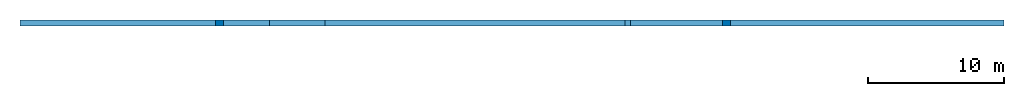
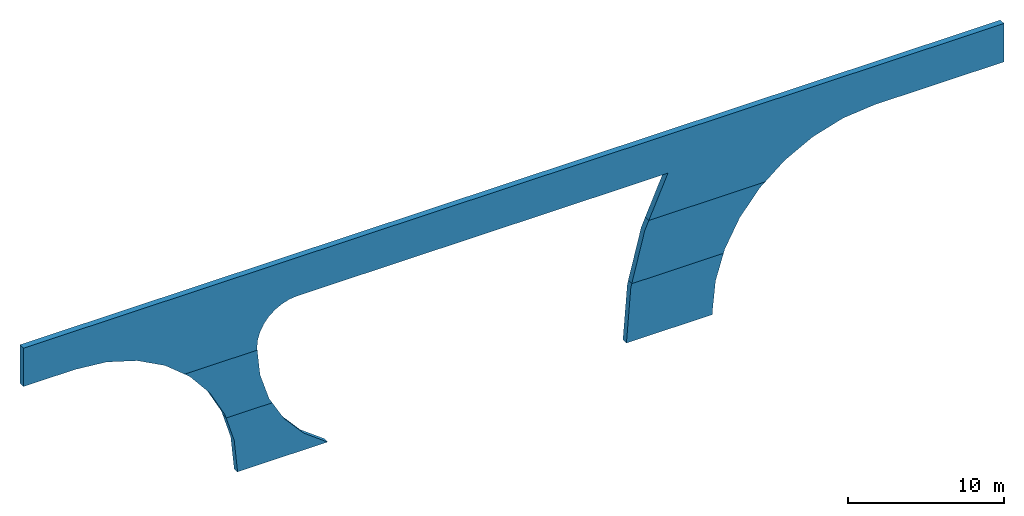
# Not in any storey: 3 walls, 9 openings.
"""IFC2X3 building model written with IfcOpenShell, lengths in millimetres."""

from ifc_helpers import new_model, entity, si_unit, converted_unit, derived_unit, direction, frame, origin_with_axes, place, context, subcontext, project, spatial, polyline, outline, extrude, faceted_brep, material, element, save


model = new_model("IFC2X3")

# Units and contexts
model_context = context("Model", 3, precision=0.1, world=origin_with_axes(), true_north=direction((0.0, 1.0)))
body_context = subcontext(model_context, "Body", "Model", "MODEL_VIEW", scale=1.0)
ifc_project = project(units=[si_unit("LENGTHUNIT", "METRE", prefix="MILLI"), si_unit("AREAUNIT", "SQUARE_METRE"), si_unit("VOLUMEUNIT", "CUBIC_METRE"), converted_unit("PLANEANGLEUNIT", "DEGREE", entity("IfcPlaneAngleMeasure", 0.0174532925199433), si_unit("PLANEANGLEUNIT", "RADIAN"), dimensions=[0, 0, 0, 0, 0, 0, 0]), si_unit("TIMEUNIT", "SECOND"), si_unit("MASSUNIT", "GRAM", prefix="KILO"), si_unit("THERMODYNAMICTEMPERATUREUNIT", "KELVIN"), derived_unit("THERMALTRANSMITTANCEUNIT", [(si_unit("POWERUNIT", "WATT"), 1), (si_unit("AREAUNIT", "SQUARE_METRE"), -1), (si_unit("THERMODYNAMICTEMPERATUREUNIT", "KELVIN"), -1)])], contexts=[model_context])

# Building
building_placement = place(None, origin_with_axes())
building = spatial("IfcBuilding", under=ifc_project, at=building_placement, CompositionType="ELEMENT")

# Wall, openings
ifc_material = material(Name="C30/37")
wall_1_placement = place(building_placement, frame((66919.2217480221, -20755.9758084029, -398.522529797108), z_axis=(3.91446519643068e-09, -1.0, 0.0), x_axis=(1.0, 3.91446519643068e-09, 0.0)))
wall_1 = element("IfcWall", 1, at=wall_1_placement, inside=building, material=ifc_material, Name="Concrete Panel", context=body_context, shape_type="SweptSolid", body=[
    extrude(outline(polyline([(0.0, 0.0), (72450.0000000238, 0.0), (72450.0000000238, 6200.0), (0.0, 6200.0), (0.0, 0.0)])), frame((-36224.9999982504, 6200.0, -450.000141801502), z_axis=(3.91446519643068e-09, 0.0, -1.0), x_axis=(1.0, 0.0, 3.91446519643068e-09)), (0.0, 0.0, -1.0), 450.0),
])
opening_1_placement = place(wall_1_placement, frame((25449.9948862458, -2899.49498149954, -10450.0000000596), z_axis=(0.0, 0.0, 1.0), x_axis=(0.0, -1.0, 0.0)))
element("IfcOpeningElement", 2, at=opening_1_placement, cuts=wall_1, Name="Poly Cut", ObjectType="Opening", context=body_context, shape_type="Brep", body=[
    faceted_brep([(5900.50501843965, -10775.005113723, -1.81898940354586e-12), (6099.50501848878, -10775.005113758, -1.81898940354586e-12), (6099.50501848878, -10775.005113758, 20000.0), (5900.50501843965, -10775.005113723, 20000.0), (6099.50501850185, 10775.0051137568, -1.81898940354586e-12), (6099.50501850185, 10775.0051137568, 20000.0), (-6099.50501850185, 10775.005113758, -1.81898940354586e-12), (-6099.50501850185, 10775.005113758, 20000.0), (-6099.50498156031, 1225.00488627701, 0.0), (-6099.50498156031, 1225.00488627701, 20000.0), (-5868.92815425188, -1116.08092881959, -1.81898940354586e-12), (-5868.92815425188, -1116.08092881959, 20000.0), (-5186.05861049108, -3367.20012893822, -1.81898940354586e-12), (-5186.05861049108, -3367.20012893822, 20000.0), (-4077.13864388699, -5441.84346566035, -1.81898940354586e-12), (-4077.13864388699, -5441.84346566035, 20000.0), (-2584.78342686672, -7260.28355902917, 0.0), (-2584.78342686672, -7260.28355902917, 20000.0), (-766.343333497909, -8752.63877604944, -3.63797880709171e-12), (-766.343333497909, -8752.63877604944, 20000.0), (1308.30000322423, -9861.55874265351, 20000.0), (3559.41920334285, -10544.4282864143, 20000.0), (3559.41920334285, -10544.4282864143, -1.81898940354586e-12), (1308.30000322423, -9861.55874265351, 0.0)], [[[0, 1, 2, 3]], [[1, 4, 5, 2]], [[4, 6, 7, 5]], [[6, 8, 9, 7]], [[8, 10, 11, 9]], [[10, 12, 13, 11]], [[12, 14, 15, 13]], [[14, 16, 17, 15]], [[16, 18, 19, 17]], [[3, 2, 5, 7, 9, 11, 13, 15, 17, 19, 20, 21]], [[6, 4, 1, 0, 22, 23, 18, 16, 14, 12, 10, 8]], [[18, 23, 20, 19]], [[23, 22, 21, 20]], [[22, 0, 3, 21]]]),
])
opening_2_placement = place(wall_1_placement, frame((-3790.85290190091, -2899.49499952649, -10449.9999999967), z_axis=(0.0, 0.0, 1.0), x_axis=(0.0, -1.0, 0.0)))
element("IfcOpeningElement", 3, at=opening_2_placement, cuts=wall_1, Name="Poly Cut", ObjectType="Opening", context=body_context, shape_type="Brep", body=[
    faceted_brep([(6099.50499853983, -9963.96619154037, 20000.0), (4777.63446104734, -11733.0569945356, 20000.0), (4777.63446104734, -11733.0569945356, -1.81898940354586e-12), (6099.50499853983, -9963.96619154037, -1.81898940354586e-12), (3121.17396848015, -13193.5920415978, 20000.0), (3121.17396848015, -13193.5920415978, 0.0), (1200.48354787124, -14283.5334598924, 20000.0), (1200.48354787124, -14283.5334598924, 0.0), (-902.853309641485, -14956.5847588002, 20000.0), (-902.853309641485, -14956.5847588002, -1.81898940354586e-12), (-3099.49499958409, -15184.1573255542, 20000.0), (-3099.49499958409, -15184.1573255542, -1.81898940354586e-12), (-3684.76791653575, -15126.5129746142, 20000.0), (-3684.76791653575, -15126.5129746142, -1.81898940354586e-12), (-4247.54912351376, -14955.7951618809, 20000.0), (-4247.54912351376, -14955.7951618809, -1.81898940354586e-12), (-4766.21125434532, -14678.5644771555, 20000.0), (-4766.21125434532, -14678.5644771555, -1.81898940354586e-12), (-5220.82241421165, -14305.4747401791, 20000.0), (-5220.82241421165, -14305.4747401791, -1.81898940354586e-12), (-5593.91215118796, -13850.8635803128, 20000.0), (-5593.91215118796, -13850.8635803128, -1.81898940354586e-12), (-5871.1428359134, -13332.2014494812, 20000.0), (-5871.1428359134, -13332.2014494812, -1.81898940354586e-12), (-6041.86064864671, -12769.4202425032, 20000.0), (-6041.86064864671, -12769.4202425032, -1.81898940354586e-12), (-6099.50499958422, -12184.1473255516, 20000.0), (-6099.50499958422, -12184.1473255516, 0.0), (-6099.50499958443, 15184.1573255373, 20000.0), (-6099.50499958443, 15184.1573255373, -1.81898940354586e-12), (-2226.97816684917, 13473.8663299848, 20000.0), (-2226.97816684917, 13473.8663299848, -1.81898940354586e-12), (6099.50499958582, 12116.6546873007, 20000.0), (1878.60032757103, 12441.4978948431, 20000.0), (6099.50499958582, 12116.6546873007, 0.0), (1878.60032757103, 12441.4978948431, -1.81898940354586e-12)], [[[0, 1, 2, 3]], [[1, 4, 5, 2]], [[4, 6, 7, 5]], [[6, 8, 9, 7]], [[8, 10, 11, 9]], [[10, 12, 13, 11]], [[12, 14, 15, 13]], [[14, 16, 17, 15]], [[16, 18, 19, 17]], [[18, 20, 21, 19]], [[20, 22, 23, 21]], [[22, 24, 25, 23]], [[24, 26, 27, 25]], [[26, 28, 29, 27]], [[28, 30, 31, 29]], [[1, 0, 32, 33, 30, 28, 26, 24, 22, 20, 18, 16, 14, 12, 10, 8, 6, 4]], [[34, 3, 2, 5, 7, 9, 11, 13, 15, 17, 19, 21, 23, 25, 27, 29, 31, 35]], [[30, 33, 35, 31]], [[33, 32, 34, 35]], [[32, 0, 3, 34]]]),
])
opening_3_placement = place(wall_1_placement, frame((-28324.9951984067, -2899.95706100758, -10449.9999999762), z_axis=(0.0, 0.0, 1.0), x_axis=(0.0, -1.0, 0.0)))
element("IfcOpeningElement", 4, at=opening_3_placement, cuts=wall_1, Name="Poly Cut", ObjectType="Opening", context=body_context, shape_type="Brep", body=[
    faceted_brep([(6099.96706100289, 7900.00497090482, 0.0), (5900.04293893701, 7900.00497091756, 0.0), (5900.04293893701, 7900.00497091756, 20000.0), (6099.96706100289, 7900.00497090482, 20000.0), (3558.95712384023, 7669.42814360913, 0.0), (3558.95712384023, 7669.42814360913, 20000.0), (1307.83792372158, 6986.55859984832, 0.0), (1307.83792372158, 6986.55859984832, 20000.0), (-766.805413000579, 5877.63863324423, 1.81898940354586e-12), (-766.805413000579, 5877.63863324423, 20000.0), (-2585.24550636941, 4385.28341622394, 0.0), (-2585.24550636941, 4385.28341622394, 20000.0), (-4077.6007233897, 2566.84332285511, 0.0), (-4077.6007233897, 2566.84332285511, 20000.0), (-5186.52068999381, 492.199986132939, 1.81898940354586e-12), (-5186.52068999381, 492.199986132939, 20000.0), (-5869.39023375461, -1758.91921398571, 0.0), (-5869.39023375461, -1758.91921398571, 20000.0), (-6099.96706106299, -4100.00502908244, 1.81898940354586e-12), (-6099.96706106299, -4100.00502908244, 20000.0), (6099.96706106305, -7900.00497091755, 20000.0), (-6099.96706106305, -7900.00494477663, 20000.0), (6099.96706106305, -7900.00497091755, 0.0), (-6099.96706106305, -7900.00494477663, 0.0)], [[[0, 1, 2, 3]], [[1, 4, 5, 2]], [[4, 6, 7, 5]], [[6, 8, 9, 7]], [[8, 10, 11, 9]], [[10, 12, 13, 11]], [[12, 14, 15, 13]], [[14, 16, 17, 15]], [[16, 18, 19, 17]], [[20, 3, 2, 5, 7, 9, 11, 13, 15, 17, 19, 21]], [[1, 0, 22, 23, 18, 16, 14, 12, 10, 8, 6, 4]], [[18, 23, 21, 19]], [[23, 22, 20, 21]], [[22, 0, 3, 20]]]),
])

wall_2_placement = place(building_placement, frame((66919.2217480221, -20755.9758084029, -4897.52252979711), z_axis=(3.91446519643068e-09, -1.0, 0.0), x_axis=(1.0, 3.91446519643068e-09, 0.0)))
wall_2 = element("IfcWall", 5, at=wall_2_placement, inside=building, material=ifc_material, Name="Concrete Panel", context=body_context, shape_type="SweptSolid", body=[
    extrude(outline(polyline([(0.0, 0.0), (72450.0000000239, 0.0), (72450.0000000239, 4500.0), (0.0, 4500.0), (0.0, 0.0)])), frame((-36224.9999982504, 4500.0, -450.000141801502), z_axis=(3.91446519643068e-09, 0.0, -1.0), x_axis=(1.0, 0.0, 3.91446519643068e-09)), (0.0, 0.0, -1.0), 450.0),
])
opening_4_placement = place(wall_2_placement, frame((-28324.9951984067, 1599.04293899242, -10450.0000000147), z_axis=(0.0, 0.0, 1.0), x_axis=(0.0, -1.0, 0.0)))
element("IfcOpeningElement", 6, at=opening_4_placement, cuts=wall_2, Name="Poly Cut", ObjectType="Opening", context=body_context, shape_type="Brep", body=[
    faceted_brep([(6099.96706100289, 7900.00497090482, 0.0), (5900.04293893701, 7900.00497091756, 0.0), (5900.04293893701, 7900.00497091756, 20000.0), (6099.96706100289, 7900.00497090482, 20000.0), (3558.95712384023, 7669.42814360913, 1.81898940354586e-12), (3558.95712384023, 7669.42814360913, 20000.0), (1307.83792372158, 6986.55859984832, 1.81898940354586e-12), (1307.83792372158, 6986.55859984832, 20000.0), (-766.805413000579, 5877.63863324423, 1.81898940354586e-12), (-766.805413000579, 5877.63863324423, 20000.0), (-2585.24550636941, 4385.28341622394, 0.0), (-2585.24550636941, 4385.28341622394, 20000.0), (-4077.6007233897, 2566.84332285511, 0.0), (-4077.6007233897, 2566.84332285511, 20000.0), (-5186.52068999381, 492.199986132939, 1.81898940354586e-12), (-5186.52068999381, 492.199986132939, 20000.0), (-5869.39023375461, -1758.91921398571, 0.0), (-5869.39023375461, -1758.91921398571, 20000.0), (-6099.96706106299, -4100.00502908244, 1.81898940354586e-12), (-6099.96706106299, -4100.00502908244, 20000.0), (6099.96706106305, -7900.00497091755, 20000.0), (-6099.96706106305, -7900.00494477663, 20000.0), (6099.96706106305, -7900.00497091755, 0.0), (-6099.96706106305, -7900.00494477663, 0.0)], [[[0, 1, 2, 3]], [[1, 4, 5, 2]], [[4, 6, 7, 5]], [[6, 8, 9, 7]], [[8, 10, 11, 9]], [[10, 12, 13, 11]], [[12, 14, 15, 13]], [[14, 16, 17, 15]], [[16, 18, 19, 17]], [[20, 3, 2, 5, 7, 9, 11, 13, 15, 17, 19, 21]], [[1, 0, 22, 23, 18, 16, 14, 12, 10, 8, 6, 4]], [[18, 23, 21, 19]], [[23, 22, 20, 21]], [[22, 0, 3, 20]]]),
])
opening_5_placement = place(wall_2_placement, frame((-3790.85290190091, 1599.50500047351, -10449.9999999905), z_axis=(0.0, 0.0, 1.0), x_axis=(0.0, -1.0, 0.0)))
element("IfcOpeningElement", 7, at=opening_5_placement, cuts=wall_2, Name="Poly Cut", ObjectType="Opening", context=body_context, shape_type="Brep", body=[
    faceted_brep([(6099.50499853983, -9963.96619154037, 20000.0), (4777.63446104734, -11733.0569945356, 20000.0), (4777.63446104734, -11733.0569945356, -1.81898940354586e-12), (6099.50499853983, -9963.96619154037, -1.81898940354586e-12), (3121.17396848015, -13193.5920415978, 20000.0), (3121.17396848015, -13193.5920415978, 1.81898940354586e-12), (1200.48354787124, -14283.5334598924, 20000.0), (1200.48354787124, -14283.5334598924, 0.0), (-902.853309641485, -14956.5847588002, 20000.0), (-902.853309641485, -14956.5847588002, 0.0), (-3099.49499958409, -15184.1573255542, 20000.0), (-3099.49499958409, -15184.1573255542, 0.0), (-3684.76791653575, -15126.5129746142, 20000.0), (-3684.76791653575, -15126.5129746142, 0.0), (-4247.54912351376, -14955.7951618809, 20000.0), (-4247.54912351376, -14955.7951618809, -1.81898940354586e-12), (-4766.21125434532, -14678.5644771555, 20000.0), (-4766.21125434532, -14678.5644771555, 0.0), (-5220.82241421165, -14305.4747401791, 20000.0), (-5220.82241421165, -14305.4747401791, 0.0), (-5593.91215118796, -13850.8635803128, 20000.0), (-5593.91215118796, -13850.8635803128, 0.0), (-5871.1428359134, -13332.2014494812, 20000.0), (-5871.1428359134, -13332.2014494812, 0.0), (-6041.86064864671, -12769.4202425032, 20000.0), (-6041.86064864671, -12769.4202425032, -1.81898940354586e-12), (-6099.50499958422, -12184.1473255516, 20000.0), (-6099.50499958422, -12184.1473255516, 0.0), (-6099.50499958443, 15184.1573255373, 20000.0), (-6099.50499958443, 15184.1573255373, 0.0), (-2226.97816684917, 13473.8663299848, 20000.0), (-2226.97816684917, 13473.8663299848, 0.0), (6099.50499958582, 12116.6546873007, 20000.0), (1878.60032757103, 12441.4978948431, 20000.0), (6099.50499958582, 12116.6546873007, 0.0), (1878.60032757103, 12441.4978948431, 0.0)], [[[0, 1, 2, 3]], [[1, 4, 5, 2]], [[4, 6, 7, 5]], [[6, 8, 9, 7]], [[8, 10, 11, 9]], [[10, 12, 13, 11]], [[12, 14, 15, 13]], [[14, 16, 17, 15]], [[16, 18, 19, 17]], [[18, 20, 21, 19]], [[20, 22, 23, 21]], [[22, 24, 25, 23]], [[24, 26, 27, 25]], [[26, 28, 29, 27]], [[28, 30, 31, 29]], [[1, 0, 32, 33, 30, 28, 26, 24, 22, 20, 18, 16, 14, 12, 10, 8, 6, 4]], [[34, 3, 2, 5, 7, 9, 11, 13, 15, 17, 19, 21, 23, 25, 27, 29, 31, 35]], [[30, 33, 35, 31]], [[33, 32, 34, 35]], [[32, 0, 3, 34]]]),
])
opening_6_placement = place(wall_2_placement, frame((25449.9948862458, 1599.50501850046, -10450.0000000149), z_axis=(0.0, 0.0, 1.0), x_axis=(0.0, -1.0, 0.0)))
element("IfcOpeningElement", 8, at=opening_6_placement, cuts=wall_2, Name="Poly Cut", ObjectType="Opening", context=body_context, shape_type="Brep", body=[
    faceted_brep([(5900.50501843965, -10775.005113723, 0.0), (6099.50501848878, -10775.005113758, 0.0), (6099.50501848878, -10775.005113758, 20000.0), (5900.50501843965, -10775.005113723, 20000.0), (6099.50501850185, 10775.0051137568, 0.0), (6099.50501850185, 10775.0051137568, 20000.0), (-6099.50501850185, 10775.005113758, 0.0), (-6099.50501850185, 10775.005113758, 20000.0), (-6099.50498156031, 1225.00488627701, 0.0), (-6099.50498156031, 1225.00488627701, 20000.0), (-5868.92815425188, -1116.08092881959, 0.0), (-5868.92815425188, -1116.08092881959, 20000.0), (-5186.05861049108, -3367.20012893822, -1.81898940354586e-12), (-5186.05861049108, -3367.20012893822, 20000.0), (-4077.13864388699, -5441.84346566035, 0.0), (-4077.13864388699, -5441.84346566035, 20000.0), (-2584.78342686672, -7260.28355902917, 0.0), (-2584.78342686672, -7260.28355902917, 20000.0), (-766.343333497909, -8752.63877604944, -1.81898940354586e-12), (-766.343333497909, -8752.63877604944, 20000.0), (1308.30000322423, -9861.55874265351, 20000.0), (3559.41920334285, -10544.4282864143, 20000.0), (3559.41920334285, -10544.4282864143, -1.81898940354586e-12), (1308.30000322423, -9861.55874265351, 0.0)], [[[0, 1, 2, 3]], [[1, 4, 5, 2]], [[4, 6, 7, 5]], [[6, 8, 9, 7]], [[8, 10, 11, 9]], [[10, 12, 13, 11]], [[12, 14, 15, 13]], [[14, 16, 17, 15]], [[16, 18, 19, 17]], [[3, 2, 5, 7, 9, 11, 13, 15, 17, 19, 20, 21]], [[6, 4, 1, 0, 22, 23, 18, 16, 14, 12, 10, 8]], [[18, 23, 20, 19]], [[23, 22, 21, 20]], [[22, 0, 3, 21]]]),
])

wall_3_placement = place(building_placement, frame((66919.2217480221, -20755.9758084029, -9397.52252979711), z_axis=(3.91446519643068e-09, -1.0, 0.0), x_axis=(1.0, 3.91446519643068e-09, 0.0)))
wall_3 = element("IfcWall", 9, at=wall_3_placement, inside=building, material=ifc_material, Name="Concrete Panel", context=body_context, shape_type="SweptSolid", body=[
    extrude(outline(polyline([(0.0, 0.0), (72450.0000000238, 0.0), (72450.0000000238, 4500.0), (0.0, 4500.0), (0.0, 0.0)])), frame((-36224.9999982504, 4500.0, -450.000141801502), z_axis=(3.91446519643068e-09, 0.0, -1.0), x_axis=(1.0, 0.0, 3.91446519643068e-09)), (0.0, 0.0, -1.0), 450.0),
])
opening_7_placement = place(wall_3_placement, frame((-28324.9951984067, 6099.04293899242, -10450.0000000147), z_axis=(0.0, 0.0, 1.0), x_axis=(0.0, -1.0, 0.0)))
element("IfcOpeningElement", 10, at=opening_7_placement, cuts=wall_3, Name="Poly Cut", ObjectType="Opening", context=body_context, shape_type="Brep", body=[
    faceted_brep([(6099.96706100289, 7900.00497090482, 0.0), (5900.04293893701, 7900.00497091756, 0.0), (5900.04293893701, 7900.00497091756, 20000.0), (6099.96706100289, 7900.00497090482, 20000.0), (3558.95712384023, 7669.42814360913, 1.81898940354586e-12), (3558.95712384023, 7669.42814360913, 20000.0), (1307.83792372158, 6986.55859984832, 1.81898940354586e-12), (1307.83792372158, 6986.55859984832, 20000.0), (-766.805413000579, 5877.63863324423, 1.81898940354586e-12), (-766.805413000579, 5877.63863324423, 20000.0), (-2585.24550636941, 4385.28341622394, 0.0), (-2585.24550636941, 4385.28341622394, 20000.0), (-4077.6007233897, 2566.84332285511, 0.0), (-4077.6007233897, 2566.84332285511, 20000.0), (-5186.52068999381, 492.199986132939, 1.81898940354586e-12), (-5186.52068999381, 492.199986132939, 20000.0), (-5869.39023375461, -1758.91921398571, 0.0), (-5869.39023375461, -1758.91921398571, 20000.0), (-6099.96706106299, -4100.00502908244, 1.81898940354586e-12), (-6099.96706106299, -4100.00502908244, 20000.0), (6099.96706106305, -7900.00497091755, 20000.0), (-6099.96706106305, -7900.00494477663, 20000.0), (6099.96706106305, -7900.00497091755, 0.0), (-6099.96706106305, -7900.00494477663, 0.0)], [[[0, 1, 2, 3]], [[1, 4, 5, 2]], [[4, 6, 7, 5]], [[6, 8, 9, 7]], [[8, 10, 11, 9]], [[10, 12, 13, 11]], [[12, 14, 15, 13]], [[14, 16, 17, 15]], [[16, 18, 19, 17]], [[20, 3, 2, 5, 7, 9, 11, 13, 15, 17, 19, 21]], [[1, 0, 22, 23, 18, 16, 14, 12, 10, 8, 6, 4]], [[18, 23, 21, 19]], [[23, 22, 20, 21]], [[22, 0, 3, 20]]]),
])
opening_8_placement = place(wall_3_placement, frame((-3790.85290190091, 6099.50500047351, -10449.999999989), z_axis=(0.0, 0.0, 1.0), x_axis=(0.0, -1.0, 0.0)))
element("IfcOpeningElement", 11, at=opening_8_placement, cuts=wall_3, Name="Poly Cut", ObjectType="Opening", context=body_context, shape_type="Brep", body=[
    faceted_brep([(6099.50499853983, -9963.96619154037, 20000.0), (4777.63446104734, -11733.0569945356, 20000.0), (4777.63446104734, -11733.0569945356, -1.81898940354586e-12), (6099.50499853983, -9963.96619154037, -1.81898940354586e-12), (3121.17396848015, -13193.5920415978, 20000.0), (3121.17396848015, -13193.5920415978, 0.0), (1200.48354787124, -14283.5334598924, 20000.0), (1200.48354787124, -14283.5334598924, 0.0), (-902.853309641485, -14956.5847588002, 20000.0), (-902.853309641485, -14956.5847588002, -1.81898940354586e-12), (-3099.49499958409, -15184.1573255542, 20000.0), (-3099.49499958409, -15184.1573255542, -1.81898940354586e-12), (-3684.76791653575, -15126.5129746142, 20000.0), (-3684.76791653575, -15126.5129746142, 0.0), (-4247.54912351376, -14955.7951618809, 20000.0), (-4247.54912351376, -14955.7951618809, -1.81898940354586e-12), (-4766.21125434532, -14678.5644771555, 20000.0), (-4766.21125434532, -14678.5644771555, -1.81898940354586e-12), (-5220.82241421165, -14305.4747401791, 20000.0), (-5220.82241421165, -14305.4747401791, 0.0), (-5593.91215118796, -13850.8635803128, 20000.0), (-5593.91215118796, -13850.8635803128, -1.81898940354586e-12), (-5871.1428359134, -13332.2014494812, 20000.0), (-5871.1428359134, -13332.2014494812, -1.81898940354586e-12), (-6041.86064864671, -12769.4202425032, 20000.0), (-6041.86064864671, -12769.4202425032, -1.81898940354586e-12), (-6099.50499958422, -12184.1473255516, 20000.0), (-6099.50499958422, -12184.1473255516, 0.0), (-6099.50499958443, 15184.1573255373, 20000.0), (-6099.50499958443, 15184.1573255373, -1.81898940354586e-12), (-2226.97816684917, 13473.8663299848, 20000.0), (-2226.97816684917, 13473.8663299848, -1.81898940354586e-12), (6099.50499958582, 12116.6546873007, 20000.0), (1878.60032757103, 12441.4978948431, 20000.0), (6099.50499958582, 12116.6546873007, 0.0), (1878.60032757103, 12441.4978948431, -1.81898940354586e-12)], [[[0, 1, 2, 3]], [[1, 4, 5, 2]], [[4, 6, 7, 5]], [[6, 8, 9, 7]], [[8, 10, 11, 9]], [[10, 12, 13, 11]], [[12, 14, 15, 13]], [[14, 16, 17, 15]], [[16, 18, 19, 17]], [[18, 20, 21, 19]], [[20, 22, 23, 21]], [[22, 24, 25, 23]], [[24, 26, 27, 25]], [[26, 28, 29, 27]], [[28, 30, 31, 29]], [[1, 0, 32, 33, 30, 28, 26, 24, 22, 20, 18, 16, 14, 12, 10, 8, 6, 4]], [[34, 3, 2, 5, 7, 9, 11, 13, 15, 17, 19, 21, 23, 25, 27, 29, 31, 35]], [[30, 33, 35, 31]], [[33, 32, 34, 35]], [[32, 0, 3, 34]]]),
])
opening_9_placement = place(wall_3_placement, frame((25449.9948862458, 6099.50501850046, -10450.0000000135), z_axis=(0.0, 0.0, 1.0), x_axis=(0.0, -1.0, 0.0)))
element("IfcOpeningElement", 12, at=opening_9_placement, cuts=wall_3, Name="Poly Cut", ObjectType="Opening", context=body_context, shape_type="Brep", body=[
    faceted_brep([(5900.50501843965, -10775.005113723, -1.81898940354586e-12), (6099.50501848878, -10775.005113758, -1.81898940354586e-12), (6099.50501848878, -10775.005113758, 20000.0), (5900.50501843965, -10775.005113723, 20000.0), (6099.50501850185, 10775.0051137568, -1.81898940354586e-12), (6099.50501850185, 10775.0051137568, 20000.0), (-6099.50501850185, 10775.005113758, -1.81898940354586e-12), (-6099.50501850185, 10775.005113758, 20000.0), (-6099.50498156031, 1225.00488627701, 0.0), (-6099.50498156031, 1225.00488627701, 20000.0), (-5868.92815425188, -1116.08092881959, -1.81898940354586e-12), (-5868.92815425188, -1116.08092881959, 20000.0), (-5186.05861049108, -3367.20012893822, -3.63797880709171e-12), (-5186.05861049108, -3367.20012893822, 20000.0), (-4077.13864388699, -5441.84346566035, -1.81898940354586e-12), (-4077.13864388699, -5441.84346566035, 20000.0), (-2584.78342686672, -7260.28355902917, -1.81898940354586e-12), (-2584.78342686672, -7260.28355902917, 20000.0), (-766.343333497909, -8752.63877604944, -3.63797880709171e-12), (-766.343333497909, -8752.63877604944, 20000.0), (1308.30000322423, -9861.55874265351, 20000.0), (3559.41920334285, -10544.4282864143, 20000.0), (3559.41920334285, -10544.4282864143, -1.81898940354586e-12), (1308.30000322423, -9861.55874265351, 0.0)], [[[0, 1, 2, 3]], [[1, 4, 5, 2]], [[4, 6, 7, 5]], [[6, 8, 9, 7]], [[8, 10, 11, 9]], [[10, 12, 13, 11]], [[12, 14, 15, 13]], [[14, 16, 17, 15]], [[16, 18, 19, 17]], [[3, 2, 5, 7, 9, 11, 13, 15, 17, 19, 20, 21]], [[6, 4, 1, 0, 22, 23, 18, 16, 14, 12, 10, 8]], [[18, 23, 20, 19]], [[23, 22, 21, 20]], [[22, 0, 3, 21]]]),
])

save(model, "model.ifc")
